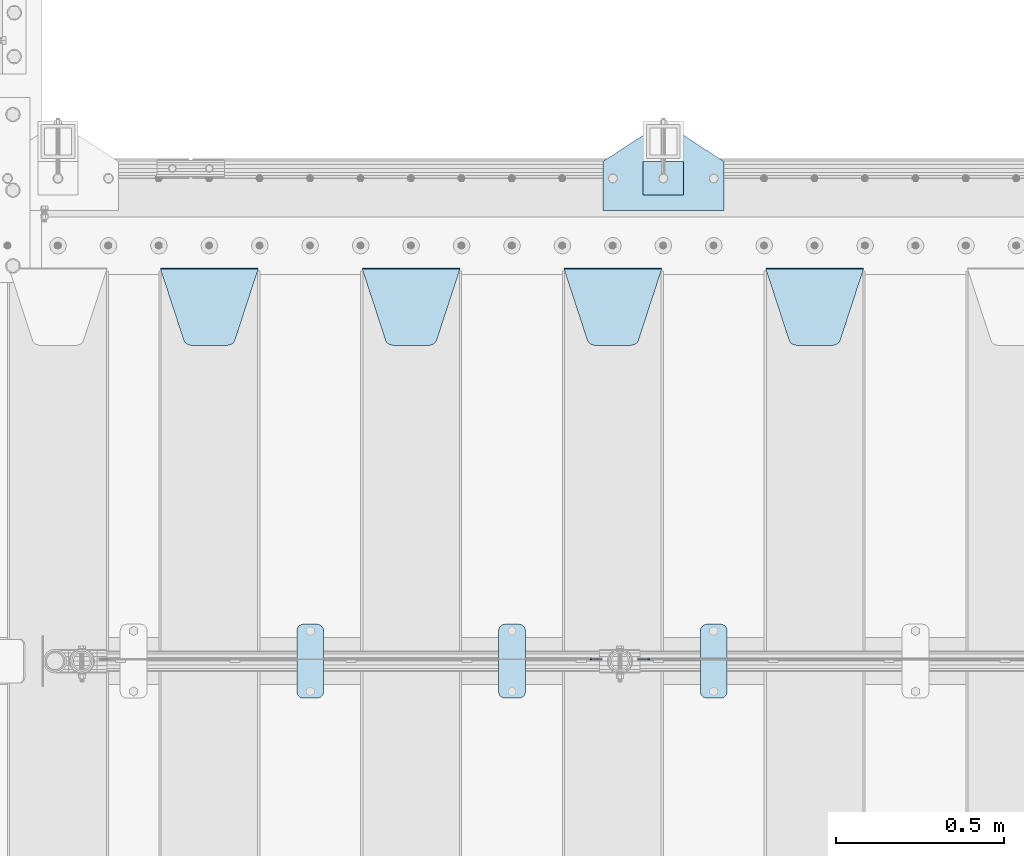
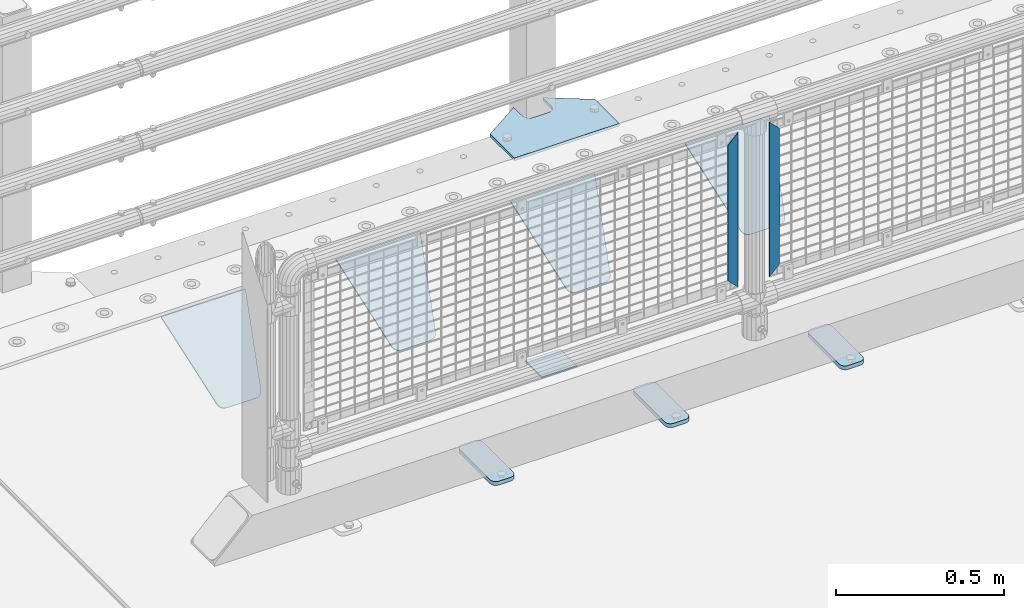
# One storey, part 213 of 247: 11 plates.
"""IFC2X3 building model written with IfcOpenShell, lengths in millimetres."""

from ifc_helpers import new_model, si_unit, frame, origin_with_axes, place, context, subcontext, project, spatial, faceted_brep, material, type_object, element, save


model = new_model("IFC2X3")

# Units and contexts
model_context = context("Model", 3, precision=1e-05, world=origin_with_axes())
body_context = subcontext(model_context, "Body", "Model", "MODEL_VIEW")
ifc_project = project(units=[si_unit("LENGTHUNIT", "METRE", prefix="MILLI"), si_unit("AREAUNIT", "SQUARE_METRE"), si_unit("VOLUMEUNIT", "CUBIC_METRE"), si_unit("MASSUNIT", "GRAM", prefix="KILO"), si_unit("TIMEUNIT", "SECOND"), si_unit("PLANEANGLEUNIT", "RADIAN"), si_unit("SOLIDANGLEUNIT", "STERADIAN"), si_unit("THERMODYNAMICTEMPERATUREUNIT", "DEGREE_CELSIUS"), si_unit("LUMINOUSINTENSITYUNIT", "LUMEN")], contexts=[model_context])

# Site, building, storey
site_placement = place(None, origin_with_axes())
site = spatial("IfcSite", under=ifc_project, at=site_placement, CompositionType="ELEMENT")
building_placement = place(site_placement, origin_with_axes())
building = spatial("IfcBuilding", under=site, at=building_placement, Name="Standard", CompositionType="ELEMENT")
storey_placement = place(building_placement, origin_with_axes())
storey = spatial("IfcBuildingStorey", under=building, at=storey_placement, Name="Undefined", CompositionType="ELEMENT", Elevation=0.0)

# Plates
ifc_material_1 = material(Name="STEEL/S355J2")
plate_type_1 = type_object("IfcPlateType", PredefinedType="NOTDEFINED")
plate_1_placement = place(storey_placement, frame((2460.0, 7774.5, 21.0199999999977), z_axis=(1.0, 0.0, 0.0), x_axis=(0.0, -0.999999999999548, -9.5100000000016e-07)))
element("IfcPlate", 1, at=plate_1_placement, inside=storey, type_object=plate_type_1, material=ifc_material_1, context=body_context, shape_type="Brep", body=[
    faceted_brep([(0.0, -7.0, 20.0), (0.0, -7.0, 60.0), (0.0, 7.0, 60.0), (0.0, 7.0, 20.0), (0.384294391935327, -7.0, 63.9018064403226), (0.384294391935327, 7.0, 63.9018064403226), (1.52240934977453, -7.0, 67.6536686473009), (1.52240934977453, 7.0, 67.6536686473009), (3.37060775394912, -7.0, 71.1114046603925), (3.37060775394912, 7.0, 71.1114046603925), (5.85786437626939, -7.0, 74.1421356237315), (5.85786437626939, 7.0, 74.1421356237315), (8.8885953396084, -7.0, 76.6293922460518), (8.8885953396084, 7.0, 76.6293922460518), (12.3463313526981, -7.0, 78.4775906502255), (12.3463313526981, 7.0, 78.4775906502255), (16.0981935596774, -7.0, 79.6157056080647), (16.0981935596774, 7.0, 79.6157056080647), (20.0, -7.0, 80.0), (20.0, 7.0, 80.0), (200.0, -7.0, 80.0), (200.0, 7.0, 80.0), (203.901806440323, -7.0, 79.6157056080647), (203.901806440323, 7.0, 79.6157056080647), (207.653668647302, -7.0, 78.4775906502255), (207.653668647302, 7.0, 78.4775906502255), (211.111404660392, -7.0, 76.6293922460518), (211.111404660392, 7.0, 76.6293922460518), (214.142135623731, -7.0, 74.1421356237315), (214.142135623731, 7.0, 74.1421356237315), (216.629392246051, -7.0, 71.1114046603925), (216.629392246051, 7.0, 71.1114046603925), (218.477590650225, -7.0, 67.6536686473009), (218.477590650225, 7.0, 67.6536686473009), (219.615705608065, -7.0, 63.9018064403226), (219.615705608065, 7.0, 63.9018064403226), (220.0, -7.0, 60.0), (220.0, 7.0, 60.0), (220.0, -7.0, 20.0), (220.0, 7.0, 20.0), (219.615705608065, -7.0, 16.0981935596774), (219.615705608065, 7.0, 16.0981935596774), (218.477590650225, -7.0, 12.3463313526991), (218.477590650225, 7.0, 12.3463313526991), (216.629392246051, -7.0, 8.88859533960749), (216.629392246051, 7.0, 8.88859533960749), (214.142135623731, -7.0, 5.85786437626848), (214.142135623731, 7.0, 5.85786437626848), (211.111404660392, -7.0, 3.37060775394821), (211.111404660392, 7.0, 3.37060775394821), (207.653668647302, -7.0, 1.52240934977453), (207.653668647302, 7.0, 1.52240934977453), (203.901806440323, -7.0, 0.384294391935327), (203.901806440323, 7.0, 0.384294391935327), (200.0, -7.0, 0.0), (200.0, 7.0, 0.0), (20.0, -7.0, 0.0), (20.0, 7.0, 0.0), (16.0981935596774, -7.0, 0.384294391935327), (16.0981935596774, 7.0, 0.384294391935327), (12.3463313526981, -7.0, 1.52240934977453), (12.3463313526981, 7.0, 1.52240934977453), (8.8885953396084, -7.0, 3.37060775394821), (8.8885953396084, 7.0, 3.37060775394821), (5.85786437626939, -7.0, 5.85786437626848), (5.85786437626939, 7.0, 5.85786437626848), (3.37060775394912, -7.0, 8.88859533960749), (3.37060775394912, 7.0, 8.88859533960749), (1.52240934977453, -7.0, 12.3463313526991), (1.52240934977453, 7.0, 12.3463313526991), (0.384294391935327, -7.0, 16.0981935596774), (0.384294391935327, 7.0, 16.0981935596774)], [[[0, 1, 2, 3]], [[1, 4, 5, 2]], [[4, 6, 7, 5]], [[6, 8, 9, 7]], [[8, 10, 11, 9]], [[10, 12, 13, 11]], [[12, 14, 15, 13]], [[14, 16, 17, 15]], [[16, 18, 19, 17]], [[18, 20, 21, 19]], [[20, 22, 23, 21]], [[22, 24, 25, 23]], [[24, 26, 27, 25]], [[26, 28, 29, 27]], [[28, 30, 31, 29]], [[30, 32, 33, 31]], [[32, 34, 35, 33]], [[34, 36, 37, 35]], [[36, 38, 39, 37]], [[38, 40, 41, 39]], [[40, 42, 43, 41]], [[42, 44, 45, 43]], [[44, 46, 47, 45]], [[46, 48, 49, 47]], [[48, 50, 51, 49]], [[50, 52, 53, 51]], [[52, 54, 55, 53]], [[54, 56, 57, 55]], [[56, 58, 59, 57]], [[58, 60, 61, 59]], [[60, 62, 63, 61]], [[62, 64, 65, 63]], [[64, 66, 67, 65]], [[66, 68, 69, 67]], [[68, 70, 71, 69]], [[70, 0, 3, 71]], [[5, 7, 9, 11, 13, 15, 17, 19, 21, 23, 25, 27, 29, 31, 33, 35, 37, 39, 41, 43, 45, 47, 49, 51, 53, 55, 57, 59, 61, 63, 65, 67, 69, 71, 3, 2]], [[70, 68, 66, 64, 62, 60, 58, 56, 54, 52, 50, 48, 46, 44, 42, 40, 38, 36, 34, 32, 30, 28, 26, 24, 22, 20, 18, 16, 14, 12, 10, 8, 6, 4, 1, 0]]]),
])
plate_2_placement = place(storey_placement, frame((1860.0, 7774.5, 21.0199999999977), z_axis=(1.0, 0.0, 0.0), x_axis=(0.0, -0.999999999999548, -9.5100000000016e-07)))
element("IfcPlate", 2, at=plate_2_placement, inside=storey, type_object=plate_type_1, material=ifc_material_1, context=body_context, shape_type="Brep", body=[
    faceted_brep([(0.0, -7.0, 20.0), (0.0, -7.0, 60.0), (0.0, 7.0, 60.0), (0.0, 7.0, 20.0), (0.384294391935327, -7.0, 63.9018064403226), (0.384294391935327, 7.0, 63.9018064403226), (1.52240934977453, -7.0, 67.6536686473009), (1.52240934977453, 7.0, 67.6536686473009), (3.37060775394912, -7.0, 71.1114046603925), (3.37060775394912, 7.0, 71.1114046603925), (5.85786437626939, -7.0, 74.1421356237315), (5.85786437626939, 7.0, 74.1421356237315), (8.8885953396084, -7.0, 76.6293922460518), (8.8885953396084, 7.0, 76.6293922460518), (12.3463313526981, -7.0, 78.4775906502255), (12.3463313526981, 7.0, 78.4775906502255), (16.0981935596774, -7.0, 79.6157056080647), (16.0981935596774, 7.0, 79.6157056080647), (20.0, -7.0, 80.0), (20.0, 7.0, 80.0), (200.0, -7.0, 80.0), (200.0, 7.0, 80.0), (203.901806440323, -7.0, 79.6157056080647), (203.901806440323, 7.0, 79.6157056080647), (207.653668647302, -7.0, 78.4775906502255), (207.653668647302, 7.0, 78.4775906502255), (211.111404660392, -7.0, 76.6293922460518), (211.111404660392, 7.0, 76.6293922460518), (214.142135623731, -7.0, 74.1421356237315), (214.142135623731, 7.0, 74.1421356237315), (216.629392246051, -7.0, 71.1114046603925), (216.629392246051, 7.0, 71.1114046603925), (218.477590650225, -7.0, 67.6536686473009), (218.477590650225, 7.0, 67.6536686473009), (219.615705608065, -7.0, 63.9018064403226), (219.615705608065, 7.0, 63.9018064403226), (220.0, -7.0, 60.0), (220.0, 7.0, 60.0), (220.0, -7.0, 20.0), (220.0, 7.0, 20.0), (219.615705608065, -7.0, 16.0981935596774), (219.615705608065, 7.0, 16.0981935596774), (218.477590650225, -7.0, 12.3463313526991), (218.477590650225, 7.0, 12.3463313526991), (216.629392246051, -7.0, 8.88859533960749), (216.629392246051, 7.0, 8.88859533960749), (214.142135623731, -7.0, 5.85786437626848), (214.142135623731, 7.0, 5.85786437626848), (211.111404660392, -7.0, 3.37060775394821), (211.111404660392, 7.0, 3.37060775394821), (207.653668647302, -7.0, 1.52240934977453), (207.653668647302, 7.0, 1.52240934977453), (203.901806440323, -7.0, 0.384294391935327), (203.901806440323, 7.0, 0.384294391935327), (200.0, -7.0, 0.0), (200.0, 7.0, 0.0), (20.0, -7.0, 0.0), (20.0, 7.0, 0.0), (16.0981935596774, -7.0, 0.384294391935327), (16.0981935596774, 7.0, 0.384294391935327), (12.3463313526981, -7.0, 1.52240934977453), (12.3463313526981, 7.0, 1.52240934977453), (8.8885953396084, -7.0, 3.37060775394821), (8.8885953396084, 7.0, 3.37060775394821), (5.85786437626939, -7.0, 5.85786437626848), (5.85786437626939, 7.0, 5.85786437626848), (3.37060775394912, -7.0, 8.88859533960749), (3.37060775394912, 7.0, 8.88859533960749), (1.52240934977453, -7.0, 12.3463313526991), (1.52240934977453, 7.0, 12.3463313526991), (0.384294391935327, -7.0, 16.0981935596774), (0.384294391935327, 7.0, 16.0981935596774)], [[[0, 1, 2, 3]], [[1, 4, 5, 2]], [[4, 6, 7, 5]], [[6, 8, 9, 7]], [[8, 10, 11, 9]], [[10, 12, 13, 11]], [[12, 14, 15, 13]], [[14, 16, 17, 15]], [[16, 18, 19, 17]], [[18, 20, 21, 19]], [[20, 22, 23, 21]], [[22, 24, 25, 23]], [[24, 26, 27, 25]], [[26, 28, 29, 27]], [[28, 30, 31, 29]], [[30, 32, 33, 31]], [[32, 34, 35, 33]], [[34, 36, 37, 35]], [[36, 38, 39, 37]], [[38, 40, 41, 39]], [[40, 42, 43, 41]], [[42, 44, 45, 43]], [[44, 46, 47, 45]], [[46, 48, 49, 47]], [[48, 50, 51, 49]], [[50, 52, 53, 51]], [[52, 54, 55, 53]], [[54, 56, 57, 55]], [[56, 58, 59, 57]], [[58, 60, 61, 59]], [[60, 62, 63, 61]], [[62, 64, 65, 63]], [[64, 66, 67, 65]], [[66, 68, 69, 67]], [[68, 70, 71, 69]], [[70, 0, 3, 71]], [[5, 7, 9, 11, 13, 15, 17, 19, 21, 23, 25, 27, 29, 31, 33, 35, 37, 39, 41, 43, 45, 47, 49, 51, 53, 55, 57, 59, 61, 63, 65, 67, 69, 71, 3, 2]], [[70, 68, 66, 64, 62, 60, 58, 56, 54, 52, 50, 48, 46, 44, 42, 40, 38, 36, 34, 32, 30, 28, 26, 24, 22, 20, 18, 16, 14, 12, 10, 8, 6, 4, 1, 0]]]),
])
plate_3_placement = place(storey_placement, frame((1260.0, 7774.5, 21.0199999999977), z_axis=(1.0, 0.0, 0.0), x_axis=(0.0, -0.999999999999548, -9.5100000000016e-07)))
element("IfcPlate", 3, at=plate_3_placement, inside=storey, type_object=plate_type_1, material=ifc_material_1, context=body_context, shape_type="Brep", body=[
    faceted_brep([(0.0, -7.0, 20.0), (0.0, -7.0, 60.0), (0.0, 7.0, 60.0), (0.0, 7.0, 20.0), (0.384294391935327, -7.0, 63.9018064403226), (0.384294391935327, 7.0, 63.9018064403226), (1.52240934977453, -7.0, 67.6536686473009), (1.52240934977453, 7.0, 67.6536686473009), (3.37060775394912, -7.0, 71.1114046603925), (3.37060775394912, 7.0, 71.1114046603925), (5.85786437626939, -7.0, 74.1421356237315), (5.85786437626939, 7.0, 74.1421356237315), (8.8885953396084, -7.0, 76.6293922460518), (8.8885953396084, 7.0, 76.6293922460518), (12.3463313526981, -7.0, 78.4775906502255), (12.3463313526981, 7.0, 78.4775906502255), (16.0981935596774, -7.0, 79.6157056080647), (16.0981935596774, 7.0, 79.6157056080647), (20.0, -7.0, 80.0), (20.0, 7.0, 80.0), (200.0, -7.0, 80.0), (200.0, 7.0, 80.0), (203.901806440323, -7.0, 79.6157056080647), (203.901806440323, 7.0, 79.6157056080647), (207.653668647302, -7.0, 78.4775906502255), (207.653668647302, 7.0, 78.4775906502255), (211.111404660392, -7.0, 76.6293922460518), (211.111404660392, 7.0, 76.6293922460518), (214.142135623731, -7.0, 74.1421356237315), (214.142135623731, 7.0, 74.1421356237315), (216.629392246051, -7.0, 71.1114046603925), (216.629392246051, 7.0, 71.1114046603925), (218.477590650225, -7.0, 67.6536686473009), (218.477590650225, 7.0, 67.6536686473009), (219.615705608065, -7.0, 63.9018064403226), (219.615705608065, 7.0, 63.9018064403226), (220.0, -7.0, 60.0), (220.0, 7.0, 60.0), (220.0, -7.0, 20.0), (220.0, 7.0, 20.0), (219.615705608065, -7.0, 16.0981935596774), (219.615705608065, 7.0, 16.0981935596774), (218.477590650225, -7.0, 12.3463313526991), (218.477590650225, 7.0, 12.3463313526991), (216.629392246051, -7.0, 8.88859533960749), (216.629392246051, 7.0, 8.88859533960749), (214.142135623731, -7.0, 5.85786437626848), (214.142135623731, 7.0, 5.85786437626848), (211.111404660392, -7.0, 3.37060775394821), (211.111404660392, 7.0, 3.37060775394821), (207.653668647302, -7.0, 1.52240934977453), (207.653668647302, 7.0, 1.52240934977453), (203.901806440323, -7.0, 0.384294391935327), (203.901806440323, 7.0, 0.384294391935327), (200.0, -7.0, 0.0), (200.0, 7.0, 0.0), (20.0, -7.0, 0.0), (20.0, 7.0, 0.0), (16.0981935596774, -7.0, 0.384294391935327), (16.0981935596774, 7.0, 0.384294391935327), (12.3463313526981, -7.0, 1.52240934977453), (12.3463313526981, 7.0, 1.52240934977453), (8.8885953396084, -7.0, 3.37060775394821), (8.8885953396084, 7.0, 3.37060775394821), (5.85786437626939, -7.0, 5.85786437626848), (5.85786437626939, 7.0, 5.85786437626848), (3.37060775394912, -7.0, 8.88859533960749), (3.37060775394912, 7.0, 8.88859533960749), (1.52240934977453, -7.0, 12.3463313526991), (1.52240934977453, 7.0, 12.3463313526991), (0.384294391935327, -7.0, 16.0981935596774), (0.384294391935327, 7.0, 16.0981935596774)], [[[0, 1, 2, 3]], [[1, 4, 5, 2]], [[4, 6, 7, 5]], [[6, 8, 9, 7]], [[8, 10, 11, 9]], [[10, 12, 13, 11]], [[12, 14, 15, 13]], [[14, 16, 17, 15]], [[16, 18, 19, 17]], [[18, 20, 21, 19]], [[20, 22, 23, 21]], [[22, 24, 25, 23]], [[24, 26, 27, 25]], [[26, 28, 29, 27]], [[28, 30, 31, 29]], [[30, 32, 33, 31]], [[32, 34, 35, 33]], [[34, 36, 37, 35]], [[36, 38, 39, 37]], [[38, 40, 41, 39]], [[40, 42, 43, 41]], [[42, 44, 45, 43]], [[44, 46, 47, 45]], [[46, 48, 49, 47]], [[48, 50, 51, 49]], [[50, 52, 53, 51]], [[52, 54, 55, 53]], [[54, 56, 57, 55]], [[56, 58, 59, 57]], [[58, 60, 61, 59]], [[60, 62, 63, 61]], [[62, 64, 65, 63]], [[64, 66, 67, 65]], [[66, 68, 69, 67]], [[68, 70, 71, 69]], [[70, 0, 3, 71]], [[5, 7, 9, 11, 13, 15, 17, 19, 21, 23, 25, 27, 29, 31, 33, 35, 37, 39, 41, 43, 45, 47, 49, 51, 53, 55, 57, 59, 61, 63, 65, 67, 69, 71, 3, 2]], [[70, 68, 66, 64, 62, 60, 58, 56, 54, 52, 50, 48, 46, 44, 42, 40, 38, 36, 34, 32, 30, 28, 26, 24, 22, 20, 18, 16, 14, 12, 10, 8, 6, 4, 1, 0]]]),
])
ifc_material_2 = material(Name="STEEL/S355N")
plate_type_2 = type_object("IfcPlateType", PredefinedType="NOTDEFINED")
plate_4_placement = place(storey_placement, frame((2655.0, 8831.76776695594, -1.767766952965), z_axis=(0.0, -0.707106781186548, -0.707106781186547), x_axis=(1.0, 0.0, 0.0)))
element("IfcPlate", 4, at=plate_4_placement, inside=storey, type_object=plate_type_2, material=ifc_material_2, context=body_context, shape_type="Brep", body=[
    faceted_brep([(0.0, -2.49999999999909, 0.0), (69.345504679477, -2.5, 300.17173142483), (69.345504679477, 2.50000000000091, 300.171731424831), (0.0, 2.5, -9.09494701772928e-13), (70.9274061199576, -2.5, 304.897442415399), (70.9274061199576, 2.50000000000091, 304.8974424154), (73.3818627772307, -2.49999999999909, 309.234538108527), (73.3818627772307, 2.5, 309.234538108526), (76.6187032999551, -2.5, 313.023683126102), (76.6187032999551, 2.50000000000091, 313.023683126102), (80.5190132704993, -2.49999999999909, 316.125672595371), (80.5190132704993, 2.50000000000091, 316.125672595372), (84.9395038596849, -2.49999999999909, 318.426546230476), (84.9395038596849, 2.5, 318.426546230475), (89.7177759439219, -2.5, 319.841774983274), (89.7177759439219, 2.50000000000091, 319.841774983275), (94.678286292652, -2.5, 320.319366455077), (94.678286292652, 2.50000000000091, 320.319366455077), (195.321713707348, -2.5, 320.319366455077), (195.321713707348, 2.50000000000091, 320.319366455077), (200.282224056078, -2.5, 319.841774983274), (200.282224056078, 2.50000000000091, 319.841774983275), (205.060496140315, -2.5, 318.426546230475), (205.060496140315, 2.5, 318.426546230474), (209.480986729501, -2.49999999999818, 316.12567259537), (209.480986729501, 2.50000000000091, 316.12567259537), (213.381296700045, -2.5, 313.023683126101), (213.381296700045, 2.50000000000091, 313.023683126101), (216.618137222769, -2.5, 309.234538108525), (216.618137222769, 2.5, 309.234538108525), (219.072593880042, -2.49999999999909, 304.897442415398), (219.072593880042, 2.5, 304.897442415398), (220.654495320523, -2.5, 300.17173142483), (220.654495320523, 2.50000000000091, 300.171731424831), (290.0, -2.49999999999909, 0.0), (290.0, 2.5, -9.09494701772928e-13)], [[[0, 1, 2, 3]], [[1, 4, 5, 2]], [[4, 6, 7, 5]], [[6, 8, 9, 7]], [[8, 10, 11, 9]], [[10, 12, 13, 11]], [[12, 14, 15, 13]], [[14, 16, 17, 15]], [[16, 18, 19, 17]], [[18, 20, 21, 19]], [[20, 22, 23, 21]], [[22, 24, 25, 23]], [[24, 26, 27, 25]], [[26, 28, 29, 27]], [[28, 30, 31, 29]], [[30, 32, 33, 31]], [[32, 34, 35, 33]], [[34, 0, 3, 35]], [[5, 7, 9, 11, 13, 15, 17, 19, 21, 23, 25, 27, 29, 31, 33, 35, 3, 2]], [[34, 32, 30, 28, 26, 24, 22, 20, 18, 16, 14, 12, 10, 8, 6, 4, 1, 0]]]),
])
plate_5_placement = place(storey_placement, frame((2055.0, 8831.76776695594, -1.767766952965), z_axis=(0.0, -0.707106781186548, -0.707106781186547), x_axis=(1.0, 0.0, 0.0)))
element("IfcPlate", 5, at=plate_5_placement, inside=storey, type_object=plate_type_2, material=ifc_material_2, context=body_context, shape_type="Brep", body=[
    faceted_brep([(0.0, -2.49999999999909, 0.0), (69.345504679477, -2.5, 300.17173142483), (69.345504679477, 2.50000000000091, 300.171731424831), (0.0, 2.5, -9.09494701772928e-13), (70.9274061199576, -2.5, 304.897442415399), (70.9274061199576, 2.50000000000091, 304.8974424154), (73.3818627772307, -2.49999999999909, 309.234538108527), (73.3818627772307, 2.5, 309.234538108526), (76.6187032999551, -2.5, 313.023683126102), (76.6187032999551, 2.50000000000091, 313.023683126102), (80.5190132704993, -2.49999999999909, 316.125672595371), (80.5190132704993, 2.50000000000091, 316.125672595372), (84.9395038596849, -2.49999999999909, 318.426546230476), (84.9395038596849, 2.5, 318.426546230475), (89.7177759439219, -2.5, 319.841774983274), (89.7177759439219, 2.50000000000091, 319.841774983275), (94.678286292652, -2.5, 320.319366455077), (94.678286292652, 2.50000000000091, 320.319366455077), (195.321713707348, -2.5, 320.319366455077), (195.321713707348, 2.50000000000091, 320.319366455077), (200.282224056078, -2.5, 319.841774983274), (200.282224056078, 2.50000000000091, 319.841774983275), (205.060496140315, -2.5, 318.426546230475), (205.060496140315, 2.5, 318.426546230474), (209.480986729501, -2.49999999999818, 316.12567259537), (209.480986729501, 2.50000000000091, 316.12567259537), (213.381296700045, -2.5, 313.023683126101), (213.381296700045, 2.50000000000091, 313.023683126101), (216.618137222769, -2.5, 309.234538108525), (216.618137222769, 2.5, 309.234538108525), (219.072593880042, -2.49999999999909, 304.897442415398), (219.072593880042, 2.5, 304.897442415398), (220.654495320523, -2.5, 300.17173142483), (220.654495320523, 2.50000000000091, 300.171731424831), (290.0, -2.49999999999909, 0.0), (290.0, 2.5, -9.09494701772928e-13)], [[[0, 1, 2, 3]], [[1, 4, 5, 2]], [[4, 6, 7, 5]], [[6, 8, 9, 7]], [[8, 10, 11, 9]], [[10, 12, 13, 11]], [[12, 14, 15, 13]], [[14, 16, 17, 15]], [[16, 18, 19, 17]], [[18, 20, 21, 19]], [[20, 22, 23, 21]], [[22, 24, 25, 23]], [[24, 26, 27, 25]], [[26, 28, 29, 27]], [[28, 30, 31, 29]], [[30, 32, 33, 31]], [[32, 34, 35, 33]], [[34, 0, 3, 35]], [[5, 7, 9, 11, 13, 15, 17, 19, 21, 23, 25, 27, 29, 31, 33, 35, 3, 2]], [[34, 32, 30, 28, 26, 24, 22, 20, 18, 16, 14, 12, 10, 8, 6, 4, 1, 0]]]),
])
plate_6_placement = place(storey_placement, frame((1455.0, 8831.76776695594, -1.767766952965), z_axis=(0.0, -0.707106781186548, -0.707106781186547), x_axis=(1.0, 0.0, 0.0)))
element("IfcPlate", 6, at=plate_6_placement, inside=storey, type_object=plate_type_2, material=ifc_material_2, context=body_context, shape_type="Brep", body=[
    faceted_brep([(0.0, -2.49999999999909, 0.0), (69.345504679477, -2.5, 300.17173142483), (69.345504679477, 2.50000000000091, 300.171731424831), (0.0, 2.5, -9.09494701772928e-13), (70.9274061199576, -2.5, 304.897442415399), (70.9274061199576, 2.50000000000091, 304.8974424154), (73.3818627772307, -2.49999999999909, 309.234538108527), (73.3818627772307, 2.5, 309.234538108526), (76.6187032999551, -2.5, 313.023683126102), (76.6187032999551, 2.50000000000091, 313.023683126102), (80.5190132704993, -2.49999999999909, 316.125672595371), (80.5190132704993, 2.50000000000091, 316.125672595372), (84.9395038596849, -2.49999999999909, 318.426546230476), (84.9395038596849, 2.5, 318.426546230475), (89.7177759439219, -2.5, 319.841774983274), (89.7177759439219, 2.50000000000091, 319.841774983275), (94.678286292652, -2.5, 320.319366455077), (94.678286292652, 2.50000000000091, 320.319366455077), (195.321713707348, -2.5, 320.319366455077), (195.321713707348, 2.50000000000091, 320.319366455077), (200.282224056078, -2.5, 319.841774983274), (200.282224056078, 2.50000000000091, 319.841774983275), (205.060496140315, -2.5, 318.426546230475), (205.060496140315, 2.5, 318.426546230474), (209.480986729501, -2.49999999999818, 316.12567259537), (209.480986729501, 2.50000000000091, 316.12567259537), (213.381296700045, -2.5, 313.023683126101), (213.381296700045, 2.50000000000091, 313.023683126101), (216.618137222769, -2.5, 309.234538108525), (216.618137222769, 2.5, 309.234538108525), (219.072593880042, -2.49999999999909, 304.897442415398), (219.072593880042, 2.5, 304.897442415398), (220.654495320523, -2.5, 300.17173142483), (220.654495320523, 2.50000000000091, 300.171731424831), (290.0, -2.49999999999909, 0.0), (290.0, 2.5, -9.09494701772928e-13)], [[[0, 1, 2, 3]], [[1, 4, 5, 2]], [[4, 6, 7, 5]], [[6, 8, 9, 7]], [[8, 10, 11, 9]], [[10, 12, 13, 11]], [[12, 14, 15, 13]], [[14, 16, 17, 15]], [[16, 18, 19, 17]], [[18, 20, 21, 19]], [[20, 22, 23, 21]], [[22, 24, 25, 23]], [[24, 26, 27, 25]], [[26, 28, 29, 27]], [[28, 30, 31, 29]], [[30, 32, 33, 31]], [[32, 34, 35, 33]], [[34, 0, 3, 35]], [[5, 7, 9, 11, 13, 15, 17, 19, 21, 23, 25, 27, 29, 31, 33, 35, 3, 2]], [[34, 32, 30, 28, 26, 24, 22, 20, 18, 16, 14, 12, 10, 8, 6, 4, 1, 0]]]),
])
plate_7_placement = place(storey_placement, frame((855.0, 8831.76776695594, -1.767766952965), z_axis=(0.0, -0.707106781186548, -0.707106781186547), x_axis=(1.0, 0.0, 0.0)))
element("IfcPlate", 7, at=plate_7_placement, inside=storey, type_object=plate_type_2, material=ifc_material_2, context=body_context, shape_type="Brep", body=[
    faceted_brep([(0.0, -2.49999999999909, 0.0), (69.345504679477, -2.5, 300.17173142483), (69.345504679477, 2.50000000000091, 300.171731424831), (0.0, 2.5, -9.09494701772928e-13), (70.9274061199576, -2.5, 304.897442415399), (70.9274061199576, 2.50000000000091, 304.8974424154), (73.3818627772307, -2.49999999999909, 309.234538108527), (73.3818627772307, 2.5, 309.234538108526), (76.6187032999551, -2.5, 313.023683126102), (76.6187032999551, 2.50000000000091, 313.023683126102), (80.5190132704993, -2.49999999999909, 316.125672595371), (80.5190132704993, 2.50000000000091, 316.125672595372), (84.9395038596849, -2.49999999999909, 318.426546230476), (84.9395038596849, 2.5, 318.426546230475), (89.7177759439219, -2.5, 319.841774983274), (89.7177759439219, 2.50000000000091, 319.841774983275), (94.678286292652, -2.5, 320.319366455077), (94.678286292652, 2.50000000000091, 320.319366455077), (195.321713707348, -2.5, 320.319366455077), (195.321713707348, 2.50000000000091, 320.319366455077), (200.282224056078, -2.5, 319.841774983274), (200.282224056078, 2.50000000000091, 319.841774983275), (205.060496140315, -2.5, 318.426546230475), (205.060496140315, 2.5, 318.426546230474), (209.480986729501, -2.49999999999818, 316.12567259537), (209.480986729501, 2.50000000000091, 316.12567259537), (213.381296700045, -2.5, 313.023683126101), (213.381296700045, 2.50000000000091, 313.023683126101), (216.618137222769, -2.5, 309.234538108525), (216.618137222769, 2.5, 309.234538108525), (219.072593880042, -2.49999999999909, 304.897442415398), (219.072593880042, 2.5, 304.897442415398), (220.654495320523, -2.5, 300.17173142483), (220.654495320523, 2.50000000000091, 300.171731424831), (290.0, -2.49999999999909, 0.0), (290.0, 2.5, -9.09494701772928e-13)], [[[0, 1, 2, 3]], [[1, 4, 5, 2]], [[4, 6, 7, 5]], [[6, 8, 9, 7]], [[8, 10, 11, 9]], [[10, 12, 13, 11]], [[12, 14, 15, 13]], [[14, 16, 17, 15]], [[16, 18, 19, 17]], [[18, 20, 21, 19]], [[20, 22, 23, 21]], [[22, 24, 25, 23]], [[24, 26, 27, 25]], [[26, 28, 29, 27]], [[28, 30, 31, 29]], [[30, 32, 33, 31]], [[32, 34, 35, 33]], [[34, 0, 3, 35]], [[5, 7, 9, 11, 13, 15, 17, 19, 21, 23, 25, 27, 29, 31, 33, 35, 3, 2]], [[34, 32, 30, 28, 26, 24, 22, 20, 18, 16, 14, 12, 10, 8, 6, 4, 1, 0]]]),
])
ifc_material_3 = material(Name="Misc_Undefined")
plate_type_3 = type_object("IfcPlateType", PredefinedType="NOTDEFINED")
plate_8_placement = place(storey_placement, frame((2309.50971354097, 7670.5, 879.519963133601), z_axis=(-0.707008801899319, 0.0, -0.707204746899291), x_axis=(-0.707204746899294, 0.0, 0.707008801899315)))
element("IfcPlate", 8, at=plate_8_placement, inside=storey, type_object=plate_type_3, material=ifc_material_3, context=body_context, shape_type="Brep", body=[
    faceted_brep([(1.81898940354586e-12, -1.5, -5.6843418860808e-14), (-348.552185058596, -1.5, 348.655029296875), (-348.552185058596, 1.5, 348.655029296875), (1.81898940354586e-12, 1.5, -5.6843418860808e-14), (-348.544891357424, -1.5, 398.152496337891), (-348.544891357424, 1.5, 398.152496337891), (49.50439453125, -1.5, 7.6397554948926e-11), (49.50439453125, 1.5, 7.6397554948926e-11)], [[[0, 1, 2, 3]], [[1, 4, 5, 2]], [[4, 6, 7, 5]], [[6, 0, 3, 7]], [[5, 7, 3, 2]], [[6, 4, 1, 0]]]),
])
plate_9_placement = place(storey_placement, frame((2132.49968748361, 7670.5, 879.52), z_axis=(0.707103624179499, 0.0, -0.707109938179501), x_axis=(0.707109938179497, 0.0, 0.707103624179503)))
element("IfcPlate", 9, at=plate_9_placement, inside=storey, type_object=plate_type_3, material=ifc_material_3, context=body_context, shape_type="Brep", body=[
    faceted_brep([(1.81898940354586e-12, -1.5, -5.6843418860808e-14), (-348.605163574215, -1.5, 348.60208129883), (-348.605163574215, 1.5, 348.60208129883), (1.81898940354586e-12, 1.5, -5.6843418860808e-14), (-348.605163574215, -1.5, 398.099334716799), (-348.605163574215, 1.5, 398.099334716799), (49.4976959228497, -1.5, 7.09405867382884e-11), (49.4976959228497, 1.5, 7.09405867382884e-11)], [[[0, 1, 2, 3]], [[1, 4, 5, 2]], [[4, 6, 7, 5]], [[6, 0, 3, 7]], [[5, 7, 3, 2]], [[6, 4, 1, 0]]]),
])
plate_type_4 = type_object("IfcPlateType", PredefinedType="NOTDEFINED")
plate_10_placement = place(storey_placement, frame((2170.0, 9005.0, 5.00000000004911), z_axis=(0.0, 1.0, 0.0), x_axis=(1.0, 0.0, 0.0)))
element("IfcPlate", 10, at=plate_10_placement, inside=storey, type_object=plate_type_4, material=ifc_material_1, context=body_context, shape_type="Brep", body=[
    faceted_brep([(9.04219632502645e-09, -5.00000000143385, -2.89173840428703e-09), (2.31396552408114e-06, -5.0, 145.0), (2.31396552408114e-06, 5.0, 145.0), (7.66340235713869e-09, 4.99999999856618, -2.89173840428703e-09), (130.0, -5.0, 230.0), (130.0, 5.0, 230.0), (130.0, -5.0, 180.0), (130.0, 5.0, 180.0), (130.48036798992, -5.0, 175.122741949597), (130.48036798992, 5.0, 175.122741949597), (131.903011687218, -5.0, 170.432914190873), (131.903011687218, 5.0, 170.432914190873), (134.213259692437, -5.0, 166.11074417451), (134.213259692437, 5.0, 166.11074417451), (137.322330470337, -5.0, 162.322330470337), (137.322330470337, 5.0, 162.322330470337), (141.11074417451, -5.0, 159.213259692437), (141.11074417451, 5.0, 159.213259692437), (145.432914190873, -5.0, 156.903011687218), (145.432914190873, 5.0, 156.903011687218), (150.122741949597, -5.0, 155.48036798992), (150.122741949597, 5.0, 155.48036798992), (155.0, -5.0, 155.0), (155.0, 5.0, 155.0), (205.0, -5.0, 155.0), (205.0, 5.0, 155.0), (209.877258050403, -5.0, 155.48036798992), (209.877258050403, 5.0, 155.48036798992), (214.567085809127, -5.0, 156.903011687218), (214.567085809127, 5.0, 156.903011687218), (218.88925582549, -5.0, 159.213259692437), (218.88925582549, 5.0, 159.213259692437), (222.677669529663, -5.0, 162.322330470337), (222.677669529663, 5.0, 162.322330470337), (225.786740307563, -5.0, 166.11074417451), (225.786740307563, 5.0, 166.11074417451), (228.096988312782, -5.0, 170.432914190873), (228.096988312782, 5.0, 170.432914190873), (229.51963201008, -5.0, 175.122741949597), (229.51963201008, 5.0, 175.122741949597), (230.0, -5.0, 180.0), (230.0, 5.0, 180.0), (230.0, -5.0, 230.0), (230.0, 5.0, 230.0), (360.0, -5.0, 145.0), (360.0, 5.0, 145.0), (360.0, -5.0, -7.27595761418343e-12), (360.0, 5.0, -7.27595761418343e-12)], [[[0, 1, 2, 3]], [[1, 4, 5, 2]], [[4, 6, 7, 5]], [[6, 8, 9, 7]], [[8, 10, 11, 9]], [[10, 12, 13, 11]], [[12, 14, 15, 13]], [[14, 16, 17, 15]], [[16, 18, 19, 17]], [[18, 20, 21, 19]], [[20, 22, 23, 21]], [[22, 24, 25, 23]], [[24, 26, 27, 25]], [[26, 28, 29, 27]], [[28, 30, 31, 29]], [[30, 32, 33, 31]], [[32, 34, 35, 33]], [[34, 36, 37, 35]], [[36, 38, 39, 37]], [[38, 40, 41, 39]], [[40, 42, 43, 41]], [[42, 44, 45, 43]], [[44, 46, 47, 45]], [[46, 0, 3, 47]], [[5, 7, 9, 11, 13, 15, 17, 19, 21, 23, 25, 27, 29, 31, 33, 35, 37, 39, 41, 43, 45, 47, 3, 2]], [[46, 44, 42, 40, 38, 36, 34, 32, 30, 28, 26, 24, 22, 20, 18, 16, 14, 12, 10, 8, 6, 4, 1, 0]]]),
])
plate_type_5 = type_object("IfcPlateType", PredefinedType="NOTDEFINED")
plate_11_placement = place(storey_placement, frame((2290.00000000014, 9050.00000000021, -857.500000000002), z_axis=(0.0, 1.0, 0.0), x_axis=(1.0, 0.0, 0.0)))
element("IfcPlate", 11, at=plate_11_placement, inside=storey, type_object=plate_type_5, material=ifc_material_1, context=body_context, shape_type="Brep", body=[
    faceted_brep([(0.0, -2.49999999999909, 0.0), (0.0, -2.5, 100.0), (0.0, 2.5, 100.0), (0.0, 2.5, -9.09494701772928e-13), (120.0, -2.5, 100.0), (120.0, 2.5, 100.0), (120.0, -2.5, 0.0), (120.0, 2.5, 0.0)], [[[0, 1, 2, 3]], [[1, 4, 5, 2]], [[4, 6, 7, 5]], [[6, 0, 3, 7]], [[5, 7, 3, 2]], [[6, 4, 1, 0]]]),
])

save(model, "model.ifc")
